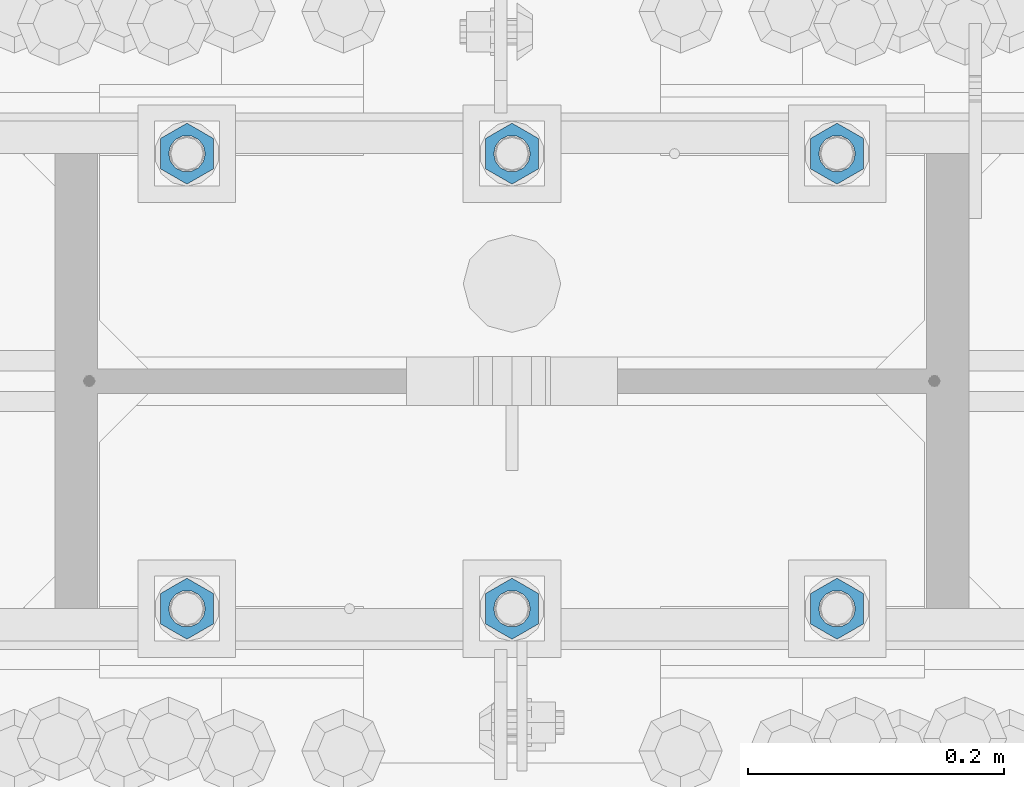
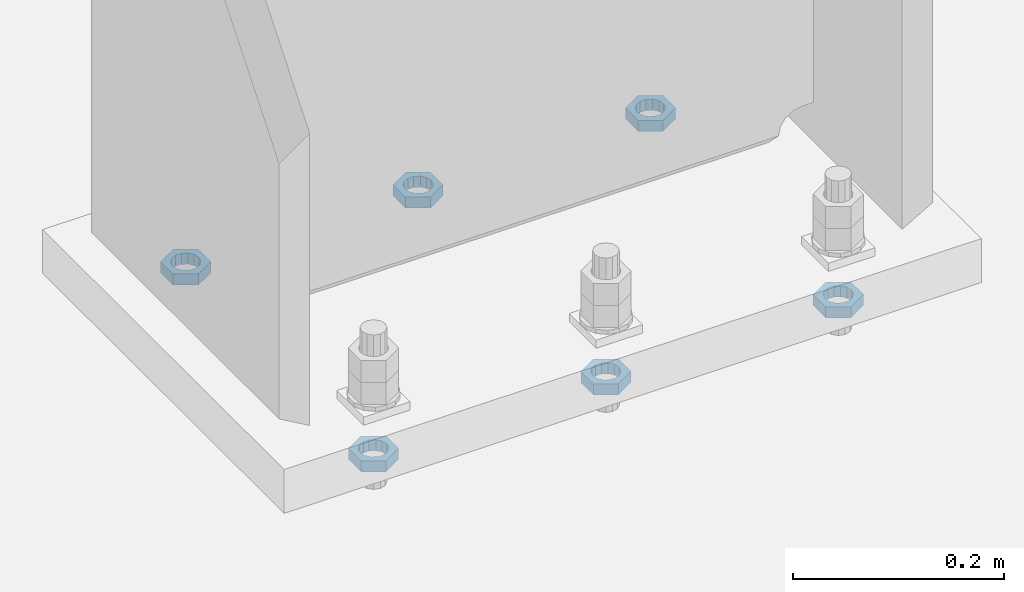
# One storey, part 1404 of 1763: 6 beams, 1 element without a shape of its own.
"""IFC2X3 building model written with IfcOpenShell, lengths in millimetres."""

from ifc_helpers import new_model, si_unit, frame, origin_with_axes, place, context, subcontext, project, spatial, faceted_brep, material, type_object, element, aggregate, save


model = new_model("IFC2X3")

# Units and contexts
model_context = context("Model", 3, precision=1e-05, world=origin_with_axes())
body_context = subcontext(model_context, "Body", "Model", "MODEL_VIEW")
ifc_project = project(units=[si_unit("LENGTHUNIT", "METRE", prefix="MILLI"), si_unit("AREAUNIT", "SQUARE_METRE"), si_unit("VOLUMEUNIT", "CUBIC_METRE"), si_unit("MASSUNIT", "GRAM", prefix="KILO"), si_unit("TIMEUNIT", "SECOND"), si_unit("PLANEANGLEUNIT", "RADIAN"), si_unit("SOLIDANGLEUNIT", "STERADIAN"), si_unit("THERMODYNAMICTEMPERATUREUNIT", "DEGREE_CELSIUS"), si_unit("LUMINOUSINTENSITYUNIT", "LUMEN")], contexts=[model_context])

# Site, building, storey
site_placement = place(None, origin_with_axes())
site = spatial("IfcSite", under=ifc_project, at=site_placement, CompositionType="ELEMENT")
building_placement = place(site_placement, origin_with_axes())
building = spatial("IfcBuilding", under=site, at=building_placement, Name="Undefined", CompositionType="ELEMENT")
storey_placement = place(building_placement, origin_with_axes())
storey = spatial("IfcBuildingStorey", under=building, at=storey_placement, Name="Undefined", CompositionType="ELEMENT", Elevation=0.0)

# Assembly, beams
assembly_placement = place(storey_placement, origin_with_axes())
assembly = element("IfcElementAssembly", 1, at=assembly_placement, inside=storey, Name="TEMPLATE", AssemblyPlace="NOTDEFINED", PredefinedType="RIGID_FRAME")
ifc_material = material(Name="STEEL/A563")
beam_type = type_object("IfcBeamType", Name="1_DIA. HALF_NUT", PredefinedType="NOTDEFINED")
beam_1_placement = place(assembly_placement, frame((-72237.0372736984, 52298.6, -266.699999999999), z_axis=(-1.0, 0.0, 0.0), x_axis=(0.0, 0.0, -1.0)))
beam_1 = element("IfcBeam", 2, at=beam_1_placement, type_object=beam_type, material=ifc_material, Name="NUT", ObjectType="1_DIA. HALF_NUT", context=body_context, shape_type="Brep", body=[
    faceted_brep([(0.0, -23.8099994659424, 0.0), (0.0, -11.9099998474121, -20.6200008392334), (12.7000000000001, -11.9099998474121, -20.6200008392334), (12.7000000000001, -23.8099994659424, 0.0), (0.0, 11.9099998474121, -20.6200008392334), (12.7000000000001, 11.9099998474121, -20.6200008392334), (0.0, 23.8099994659424, 0.0), (12.7000000000001, 23.8099994659424, 0.0), (0.0, 11.9099998474121, 20.6200008392334), (12.7000000000001, 11.9099998474121, 20.6200008392334), (0.0, -11.9099998474121, 20.6200008392334), (12.7000000000001, -11.9099998474121, 20.6200008392334), (0.0, 0.0, 14.289999961853), (0.0, 6.20019861543551, 12.8748450879575), (12.7000000000001, 6.20019861543551, 12.8748450879575), (12.7000000000001, 0.0, 14.289999961853), (0.0, 11.1723718546418, 8.90966924477834), (12.7000000000001, 11.1723718546418, 8.90966924477834), (0.0, 13.9317198278877, 3.17982413774735), (12.7000000000001, 13.9317198278877, 3.17982413774735), (0.0, 13.9317198278877, -3.17982413774735), (12.7000000000001, 13.9317198278877, -3.17982413774735), (0.0, 11.1723718546418, -8.90966924477834), (12.7000000000001, 11.1723718546418, -8.90966924477834), (0.0, 6.20019861543551, -12.8748450879575), (12.7000000000001, 6.20019861543551, -12.8748450879575), (0.0, 0.0, -14.289999961853), (12.7000000000001, 0.0, -14.289999961853), (0.0, -6.20019861543551, -12.8748450879575), (12.7000000000001, -6.20019861543551, -12.8748450879575), (0.0, -11.1723718546418, -8.90966924477834), (12.7000000000001, -11.1723718546418, -8.90966924477834), (0.0, -13.9317198278877, -3.17982413774735), (12.7000000000001, -13.9317198278877, -3.17982413774735), (0.0, -13.9317198278877, 3.17982413774735), (12.7000000000001, -13.9317198278877, 3.17982413774735), (0.0, -11.1723718546418, 8.90966924477834), (12.7000000000001, -11.1723718546418, 8.90966924477834), (0.0, -6.20019861543551, 12.8748450879575), (12.7000000000001, -6.20019861543551, 12.8748450879575)], [[[0, 1, 2, 3]], [[1, 4, 5, 2]], [[4, 6, 7, 5]], [[6, 8, 9, 7]], [[8, 10, 11, 9]], [[10, 0, 3, 11]], [[12, 13, 14, 15]], [[13, 16, 17, 14]], [[16, 18, 19, 17]], [[18, 20, 21, 19]], [[20, 22, 23, 21]], [[22, 24, 25, 23]], [[24, 26, 27, 25]], [[26, 28, 29, 27]], [[28, 30, 31, 29]], [[30, 32, 33, 31]], [[32, 34, 35, 33]], [[34, 36, 37, 35]], [[36, 38, 39, 37]], [[38, 12, 15, 39]], [[5, 7, 9, 11, 3, 2], [17, 19, 21, 23, 25, 27, 29, 31, 33, 35, 37, 39, 15, 14]], [[10, 8, 6, 4, 1, 0], [38, 36, 34, 32, 30, 28, 26, 24, 22, 20, 18, 16, 13, 12]]]),
])
beam_2_placement = place(assembly_placement, frame((-72491.0372736984, 52298.6, -266.699999999999), z_axis=(-1.0, 0.0, 0.0), x_axis=(0.0, 0.0, -1.0)))
beam_2 = element("IfcBeam", 3, at=beam_2_placement, type_object=beam_type, material=ifc_material, Name="NUT", ObjectType="1_DIA. HALF_NUT", context=body_context, shape_type="Brep", body=[
    faceted_brep([(0.0, -23.8099994659424, 0.0), (0.0, -11.9099998474121, -20.6200008392334), (12.7000000000001, -11.9099998474121, -20.6200008392334), (12.7000000000001, -23.8099994659424, 0.0), (0.0, 11.9099998474121, -20.6200008392334), (12.7000000000001, 11.9099998474121, -20.6200008392334), (0.0, 23.8099994659424, 0.0), (12.7000000000001, 23.8099994659424, 0.0), (0.0, 11.9099998474121, 20.6200008392334), (12.7000000000001, 11.9099998474121, 20.6200008392334), (0.0, -11.9099998474121, 20.6200008392334), (12.7000000000001, -11.9099998474121, 20.6200008392334), (0.0, 0.0, 14.289999961853), (0.0, 6.20019861543551, 12.8748450879575), (12.7000000000001, 6.20019861543551, 12.8748450879575), (12.7000000000001, 0.0, 14.289999961853), (0.0, 11.1723718546418, 8.90966924477834), (12.7000000000001, 11.1723718546418, 8.90966924477834), (0.0, 13.9317198278877, 3.17982413774735), (12.7000000000001, 13.9317198278877, 3.17982413774735), (0.0, 13.9317198278877, -3.17982413774735), (12.7000000000001, 13.9317198278877, -3.17982413774735), (0.0, 11.1723718546418, -8.90966924477834), (12.7000000000001, 11.1723718546418, -8.90966924477834), (0.0, 6.20019861543551, -12.8748450879575), (12.7000000000001, 6.20019861543551, -12.8748450879575), (0.0, 0.0, -14.289999961853), (12.7000000000001, 0.0, -14.289999961853), (0.0, -6.20019861543551, -12.8748450879575), (12.7000000000001, -6.20019861543551, -12.8748450879575), (0.0, -11.1723718546418, -8.90966924477834), (12.7000000000001, -11.1723718546418, -8.90966924477834), (0.0, -13.9317198278877, -3.17982413774735), (12.7000000000001, -13.9317198278877, -3.17982413774735), (0.0, -13.9317198278877, 3.17982413774735), (12.7000000000001, -13.9317198278877, 3.17982413774735), (0.0, -11.1723718546418, 8.90966924477834), (12.7000000000001, -11.1723718546418, 8.90966924477834), (0.0, -6.20019861543551, 12.8748450879575), (12.7000000000001, -6.20019861543551, 12.8748450879575)], [[[0, 1, 2, 3]], [[1, 4, 5, 2]], [[4, 6, 7, 5]], [[6, 8, 9, 7]], [[8, 10, 11, 9]], [[10, 0, 3, 11]], [[12, 13, 14, 15]], [[13, 16, 17, 14]], [[16, 18, 19, 17]], [[18, 20, 21, 19]], [[20, 22, 23, 21]], [[22, 24, 25, 23]], [[24, 26, 27, 25]], [[26, 28, 29, 27]], [[28, 30, 31, 29]], [[30, 32, 33, 31]], [[32, 34, 35, 33]], [[34, 36, 37, 35]], [[36, 38, 39, 37]], [[38, 12, 15, 39]], [[5, 7, 9, 11, 3, 2], [17, 19, 21, 23, 25, 27, 29, 31, 33, 35, 37, 39, 15, 14]], [[10, 8, 6, 4, 1, 0], [38, 36, 34, 32, 30, 28, 26, 24, 22, 20, 18, 16, 13, 12]]]),
])
beam_3_placement = place(assembly_placement, frame((-72745.0372736984, 52298.6, -266.699999999999), z_axis=(-1.0, 0.0, 0.0), x_axis=(0.0, 0.0, -1.0)))
beam_3 = element("IfcBeam", 4, at=beam_3_placement, type_object=beam_type, material=ifc_material, Name="NUT", ObjectType="1_DIA. HALF_NUT", context=body_context, shape_type="Brep", body=[
    faceted_brep([(0.0, -23.8099994659424, 0.0), (0.0, -11.9099998474121, -20.6200008392334), (12.7000000000001, -11.9099998474121, -20.6200008392334), (12.7000000000001, -23.8099994659424, 0.0), (0.0, 11.9099998474121, -20.6200008392334), (12.7000000000001, 11.9099998474121, -20.6200008392334), (0.0, 23.8099994659424, 0.0), (12.7000000000001, 23.8099994659424, 0.0), (0.0, 11.9099998474121, 20.6200008392334), (12.7000000000001, 11.9099998474121, 20.6200008392334), (0.0, -11.9099998474121, 20.6200008392334), (12.7000000000001, -11.9099998474121, 20.6200008392334), (0.0, 0.0, 14.289999961853), (0.0, 6.20019861543551, 12.8748450879575), (12.7000000000001, 6.20019861543551, 12.8748450879575), (12.7000000000001, 0.0, 14.289999961853), (0.0, 11.1723718546418, 8.90966924477834), (12.7000000000001, 11.1723718546418, 8.90966924477834), (0.0, 13.9317198278877, 3.17982413774735), (12.7000000000001, 13.9317198278877, 3.17982413774735), (0.0, 13.9317198278877, -3.17982413774735), (12.7000000000001, 13.9317198278877, -3.17982413774735), (0.0, 11.1723718546418, -8.90966924477834), (12.7000000000001, 11.1723718546418, -8.90966924477834), (0.0, 6.20019861543551, -12.8748450879575), (12.7000000000001, 6.20019861543551, -12.8748450879575), (0.0, 0.0, -14.289999961853), (12.7000000000001, 0.0, -14.289999961853), (0.0, -6.20019861543551, -12.8748450879575), (12.7000000000001, -6.20019861543551, -12.8748450879575), (0.0, -11.1723718546418, -8.90966924477834), (12.7000000000001, -11.1723718546418, -8.90966924477834), (0.0, -13.9317198278877, -3.17982413774735), (12.7000000000001, -13.9317198278877, -3.17982413774735), (0.0, -13.9317198278877, 3.17982413774735), (12.7000000000001, -13.9317198278877, 3.17982413774735), (0.0, -11.1723718546418, 8.90966924477834), (12.7000000000001, -11.1723718546418, 8.90966924477834), (0.0, -6.20019861543551, 12.8748450879575), (12.7000000000001, -6.20019861543551, 12.8748450879575)], [[[0, 1, 2, 3]], [[1, 4, 5, 2]], [[4, 6, 7, 5]], [[6, 8, 9, 7]], [[8, 10, 11, 9]], [[10, 0, 3, 11]], [[12, 13, 14, 15]], [[13, 16, 17, 14]], [[16, 18, 19, 17]], [[18, 20, 21, 19]], [[20, 22, 23, 21]], [[22, 24, 25, 23]], [[24, 26, 27, 25]], [[26, 28, 29, 27]], [[28, 30, 31, 29]], [[30, 32, 33, 31]], [[32, 34, 35, 33]], [[34, 36, 37, 35]], [[36, 38, 39, 37]], [[38, 12, 15, 39]], [[5, 7, 9, 11, 3, 2], [17, 19, 21, 23, 25, 27, 29, 31, 33, 35, 37, 39, 15, 14]], [[10, 8, 6, 4, 1, 0], [38, 36, 34, 32, 30, 28, 26, 24, 22, 20, 18, 16, 13, 12]]]),
])
beam_4_placement = place(assembly_placement, frame((-72745.0372736984, 51943.0, -266.699999999999), z_axis=(1.0, 0.0, 0.0), x_axis=(0.0, 0.0, -1.0)))
beam_4 = element("IfcBeam", 5, at=beam_4_placement, type_object=beam_type, material=ifc_material, Name="NUT", ObjectType="1_DIA. HALF_NUT", context=body_context, shape_type="Brep", body=[
    faceted_brep([(0.0, -23.8099994659424, 0.0), (0.0, -11.9099998474121, -20.6200008392334), (12.7000000000001, -11.9099998474121, -20.6200008392334), (12.7000000000001, -23.8099994659424, 0.0), (0.0, 11.9099998474121, -20.6200008392334), (12.7000000000001, 11.9099998474121, -20.6200008392334), (0.0, 23.8099994659424, 0.0), (12.7000000000001, 23.8099994659424, 0.0), (0.0, 11.9099998474121, 20.6200008392334), (12.7000000000001, 11.9099998474121, 20.6200008392334), (0.0, -11.9099998474121, 20.6200008392334), (12.7000000000001, -11.9099998474121, 20.6200008392334), (0.0, 0.0, 14.289999961853), (0.0, 6.20019861543551, 12.8748450879575), (12.7000000000001, 6.20019861543551, 12.8748450879575), (12.7000000000001, 0.0, 14.289999961853), (0.0, 11.1723718546418, 8.90966924477834), (12.7000000000001, 11.1723718546418, 8.90966924477834), (0.0, 13.9317198278877, 3.17982413774735), (12.7000000000001, 13.9317198278877, 3.17982413774735), (0.0, 13.9317198278877, -3.17982413774735), (12.7000000000001, 13.9317198278877, -3.17982413774735), (0.0, 11.1723718546418, -8.90966924477834), (12.7000000000001, 11.1723718546418, -8.90966924477834), (0.0, 6.20019861543551, -12.8748450879575), (12.7000000000001, 6.20019861543551, -12.8748450879575), (0.0, 0.0, -14.289999961853), (12.7000000000001, 0.0, -14.289999961853), (0.0, -6.20019861543551, -12.8748450879575), (12.7000000000001, -6.20019861543551, -12.8748450879575), (0.0, -11.1723718546418, -8.90966924477834), (12.7000000000001, -11.1723718546418, -8.90966924477834), (0.0, -13.9317198278877, -3.17982413774735), (12.7000000000001, -13.9317198278877, -3.17982413774735), (0.0, -13.9317198278877, 3.17982413774735), (12.7000000000001, -13.9317198278877, 3.17982413774735), (0.0, -11.1723718546418, 8.90966924477834), (12.7000000000001, -11.1723718546418, 8.90966924477834), (0.0, -6.20019861543551, 12.8748450879575), (12.7000000000001, -6.20019861543551, 12.8748450879575)], [[[0, 1, 2, 3]], [[1, 4, 5, 2]], [[4, 6, 7, 5]], [[6, 8, 9, 7]], [[8, 10, 11, 9]], [[10, 0, 3, 11]], [[12, 13, 14, 15]], [[13, 16, 17, 14]], [[16, 18, 19, 17]], [[18, 20, 21, 19]], [[20, 22, 23, 21]], [[22, 24, 25, 23]], [[24, 26, 27, 25]], [[26, 28, 29, 27]], [[28, 30, 31, 29]], [[30, 32, 33, 31]], [[32, 34, 35, 33]], [[34, 36, 37, 35]], [[36, 38, 39, 37]], [[38, 12, 15, 39]], [[5, 7, 9, 11, 3, 2], [17, 19, 21, 23, 25, 27, 29, 31, 33, 35, 37, 39, 15, 14]], [[10, 8, 6, 4, 1, 0], [38, 36, 34, 32, 30, 28, 26, 24, 22, 20, 18, 16, 13, 12]]]),
])
beam_5_placement = place(assembly_placement, frame((-72491.0372736984, 51943.0, -266.699999999999), z_axis=(1.0, 0.0, 0.0), x_axis=(0.0, 0.0, -1.0)))
beam_5 = element("IfcBeam", 6, at=beam_5_placement, type_object=beam_type, material=ifc_material, Name="NUT", ObjectType="1_DIA. HALF_NUT", context=body_context, shape_type="Brep", body=[
    faceted_brep([(0.0, -23.8099994659424, 0.0), (0.0, -11.9099998474121, -20.6200008392334), (12.7000000000001, -11.9099998474121, -20.6200008392334), (12.7000000000001, -23.8099994659424, 0.0), (0.0, 11.9099998474121, -20.6200008392334), (12.7000000000001, 11.9099998474121, -20.6200008392334), (0.0, 23.8099994659424, 0.0), (12.7000000000001, 23.8099994659424, 0.0), (0.0, 11.9099998474121, 20.6200008392334), (12.7000000000001, 11.9099998474121, 20.6200008392334), (0.0, -11.9099998474121, 20.6200008392334), (12.7000000000001, -11.9099998474121, 20.6200008392334), (0.0, 0.0, 14.289999961853), (0.0, 6.20019861543551, 12.8748450879575), (12.7000000000001, 6.20019861543551, 12.8748450879575), (12.7000000000001, 0.0, 14.289999961853), (0.0, 11.1723718546418, 8.90966924477834), (12.7000000000001, 11.1723718546418, 8.90966924477834), (0.0, 13.9317198278877, 3.17982413774735), (12.7000000000001, 13.9317198278877, 3.17982413774735), (0.0, 13.9317198278877, -3.17982413774735), (12.7000000000001, 13.9317198278877, -3.17982413774735), (0.0, 11.1723718546418, -8.90966924477834), (12.7000000000001, 11.1723718546418, -8.90966924477834), (0.0, 6.20019861543551, -12.8748450879575), (12.7000000000001, 6.20019861543551, -12.8748450879575), (0.0, 0.0, -14.289999961853), (12.7000000000001, 0.0, -14.289999961853), (0.0, -6.20019861543551, -12.8748450879575), (12.7000000000001, -6.20019861543551, -12.8748450879575), (0.0, -11.1723718546418, -8.90966924477834), (12.7000000000001, -11.1723718546418, -8.90966924477834), (0.0, -13.9317198278877, -3.17982413774735), (12.7000000000001, -13.9317198278877, -3.17982413774735), (0.0, -13.9317198278877, 3.17982413774735), (12.7000000000001, -13.9317198278877, 3.17982413774735), (0.0, -11.1723718546418, 8.90966924477834), (12.7000000000001, -11.1723718546418, 8.90966924477834), (0.0, -6.20019861543551, 12.8748450879575), (12.7000000000001, -6.20019861543551, 12.8748450879575)], [[[0, 1, 2, 3]], [[1, 4, 5, 2]], [[4, 6, 7, 5]], [[6, 8, 9, 7]], [[8, 10, 11, 9]], [[10, 0, 3, 11]], [[12, 13, 14, 15]], [[13, 16, 17, 14]], [[16, 18, 19, 17]], [[18, 20, 21, 19]], [[20, 22, 23, 21]], [[22, 24, 25, 23]], [[24, 26, 27, 25]], [[26, 28, 29, 27]], [[28, 30, 31, 29]], [[30, 32, 33, 31]], [[32, 34, 35, 33]], [[34, 36, 37, 35]], [[36, 38, 39, 37]], [[38, 12, 15, 39]], [[5, 7, 9, 11, 3, 2], [17, 19, 21, 23, 25, 27, 29, 31, 33, 35, 37, 39, 15, 14]], [[10, 8, 6, 4, 1, 0], [38, 36, 34, 32, 30, 28, 26, 24, 22, 20, 18, 16, 13, 12]]]),
])
beam_6_placement = place(assembly_placement, frame((-72237.0372736984, 51943.0, -266.699999999999), z_axis=(1.0, 0.0, 0.0), x_axis=(0.0, 0.0, -1.0)))
beam_6 = element("IfcBeam", 7, at=beam_6_placement, type_object=beam_type, material=ifc_material, Name="NUT", ObjectType="1_DIA. HALF_NUT", context=body_context, shape_type="Brep", body=[
    faceted_brep([(0.0, -23.8099994659424, 0.0), (0.0, -11.9099998474121, -20.6200008392334), (12.7000000000001, -11.9099998474121, -20.6200008392334), (12.7000000000001, -23.8099994659424, 0.0), (0.0, 11.9099998474121, -20.6200008392334), (12.7000000000001, 11.9099998474121, -20.6200008392334), (0.0, 23.8099994659424, 0.0), (12.7000000000001, 23.8099994659424, 0.0), (0.0, 11.9099998474121, 20.6200008392334), (12.7000000000001, 11.9099998474121, 20.6200008392334), (0.0, -11.9099998474121, 20.6200008392334), (12.7000000000001, -11.9099998474121, 20.6200008392334), (0.0, 0.0, 14.289999961853), (0.0, 6.20019861543551, 12.8748450879575), (12.7000000000001, 6.20019861543551, 12.8748450879575), (12.7000000000001, 0.0, 14.289999961853), (0.0, 11.1723718546418, 8.90966924477834), (12.7000000000001, 11.1723718546418, 8.90966924477834), (0.0, 13.9317198278877, 3.17982413774735), (12.7000000000001, 13.9317198278877, 3.17982413774735), (0.0, 13.9317198278877, -3.17982413774735), (12.7000000000001, 13.9317198278877, -3.17982413774735), (0.0, 11.1723718546418, -8.90966924477834), (12.7000000000001, 11.1723718546418, -8.90966924477834), (0.0, 6.20019861543551, -12.8748450879575), (12.7000000000001, 6.20019861543551, -12.8748450879575), (0.0, 0.0, -14.289999961853), (12.7000000000001, 0.0, -14.289999961853), (0.0, -6.20019861543551, -12.8748450879575), (12.7000000000001, -6.20019861543551, -12.8748450879575), (0.0, -11.1723718546418, -8.90966924477834), (12.7000000000001, -11.1723718546418, -8.90966924477834), (0.0, -13.9317198278877, -3.17982413774735), (12.7000000000001, -13.9317198278877, -3.17982413774735), (0.0, -13.9317198278877, 3.17982413774735), (12.7000000000001, -13.9317198278877, 3.17982413774735), (0.0, -11.1723718546418, 8.90966924477834), (12.7000000000001, -11.1723718546418, 8.90966924477834), (0.0, -6.20019861543551, 12.8748450879575), (12.7000000000001, -6.20019861543551, 12.8748450879575)], [[[0, 1, 2, 3]], [[1, 4, 5, 2]], [[4, 6, 7, 5]], [[6, 8, 9, 7]], [[8, 10, 11, 9]], [[10, 0, 3, 11]], [[12, 13, 14, 15]], [[13, 16, 17, 14]], [[16, 18, 19, 17]], [[18, 20, 21, 19]], [[20, 22, 23, 21]], [[22, 24, 25, 23]], [[24, 26, 27, 25]], [[26, 28, 29, 27]], [[28, 30, 31, 29]], [[30, 32, 33, 31]], [[32, 34, 35, 33]], [[34, 36, 37, 35]], [[36, 38, 39, 37]], [[38, 12, 15, 39]], [[5, 7, 9, 11, 3, 2], [17, 19, 21, 23, 25, 27, 29, 31, 33, 35, 37, 39, 15, 14]], [[10, 8, 6, 4, 1, 0], [38, 36, 34, 32, 30, 28, 26, 24, 22, 20, 18, 16, 13, 12]]]),
])
aggregate(assembly, [beam_1, beam_2, beam_3, beam_4, beam_5, beam_6])

save(model, "model.ifc")
